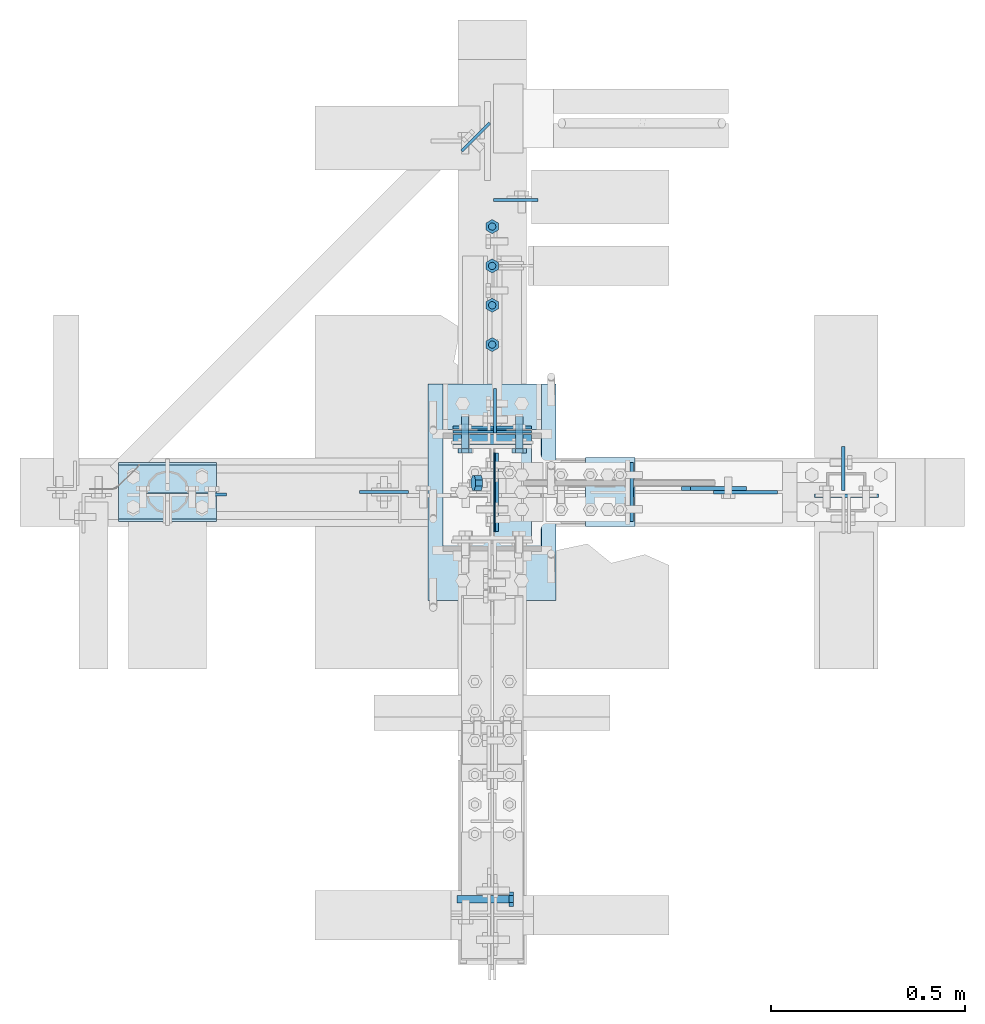
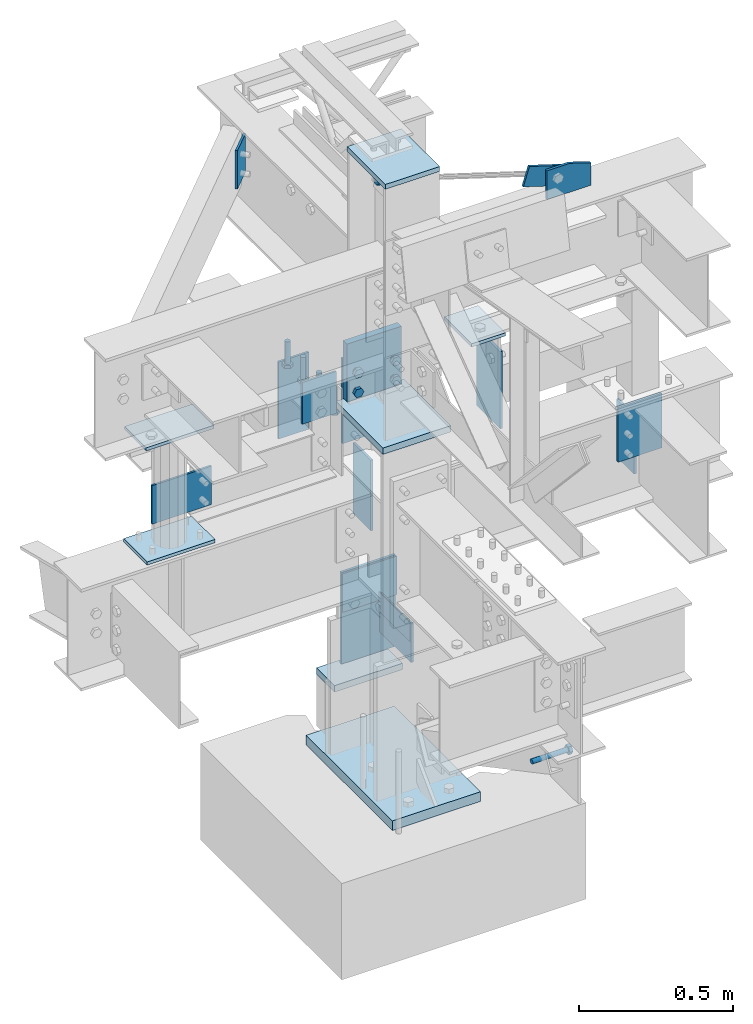
# Not in any storey, part 4 of 8: 24 plates, 9 mechanical fasteners, 13 elements without a shape of their own.
"""IFC2X3 building model written with IfcOpenShell, lengths in inches."""

from ifc_helpers import new_model, entity, si_unit, converted_unit, frame, origin_with_axes, origin_2d_with_axis, place, context, project, spatial, polyline, circle, outline, extrude, faceted_brep, source, transform, mapped, material, type_object, type_shapes, element, aggregate, save


model = new_model("IFC2X3")

# Units and contexts
model_context = context("Model", 3, precision=1e-05, world=origin_with_axes())
ifc_project = project(units=[converted_unit("LENGTHUNIT", "INCH", entity("IfcLengthMeasure", 25.4), si_unit("LENGTHUNIT", "METRE", prefix="MILLI"), dimensions=[1, 0, 0, 0, 0, 0, 0]), si_unit("PLANEANGLEUNIT", "RADIAN"), si_unit("MASSUNIT", "GRAM", prefix="KILO"), si_unit("TIMEUNIT", "SECOND"), si_unit("AREAUNIT", "SQUARE_METRE"), si_unit("PRESSUREUNIT", "PASCAL"), si_unit("FORCEUNIT", "NEWTON"), si_unit("THERMODYNAMICTEMPERATUREUNIT", "DEGREE_CELSIUS")], contexts=[model_context])

# Site, building
site_placement = place(None, origin_with_axes())
site = spatial("IfcSite", under=ifc_project, at=site_placement, CompositionType="ELEMENT")
building_placement = place(site_placement, origin_with_axes())
building = spatial("IfcBuilding", under=site, at=building_placement, Name="Building", CompositionType="ELEMENT")

# Assembly, plates
assembly_1_placement = place(building_placement, frame((23.9999999999998, 0.9375, 83.0), z_axis=(0.0, 1.0, 0.0), x_axis=(-0.954479957764932, 0.0, 0.29827505800024)))
assembly_1 = element("IfcElementAssembly", 1, at=assembly_1_placement, inside=building, Name="4-7", PredefinedType="NOTDEFINED")
ifc_material_1 = material()
plate_type_1 = type_object("IfcPlateType", Name="Plate (Complex)", PredefinedType="SHEET", material=ifc_material_1)
shared_shape_1 = source(origin_with_axes(), model_context, "Body", "Brep", [
    faceted_brep([(-0.375, 0.0, -1.0625), (-0.375, -0.438, -1.5), (-0.375, -1.0625, -1.5), (-0.375, -1.5, -1.0625), (-0.375, -1.5, -0.438), (-0.375, -1.0625, 0.0), (-0.375, -0.438, 0.0), (-0.375, 0.0, -0.438), (0.375, 0.0, -0.438), (0.375, -0.438, 0.0), (0.375, -1.0625, 0.0), (0.375, -1.5, -0.438), (0.375, -1.5, -1.0625), (0.375, -1.0625, -1.5), (0.375, -0.438, -1.5), (0.375, 0.0, -1.0625)], [[[0, 1, 2, 3, 4, 5, 6, 7]], [[8, 9, 10, 11, 12, 13, 14, 15]], [[15, 14, 1, 0]], [[14, 13, 2, 1]], [[13, 12, 3, 2]], [[12, 11, 4, 3]], [[11, 10, 5, 4]], [[10, 9, 6, 5]], [[9, 8, 7, 6]], [[8, 15, 0, 7]]]),
])
type_shapes(plate_type_1, [shared_shape_1])
plate_1_placement = place(assembly_1_placement, frame((26.7744260805885, 0.749994139208951, 0.75), z_axis=(0.0, 0.0, 1.0), x_axis=(1.0, 0.0, 0.0)))
plate_1 = element("IfcPlate", 2, at=plate_1_placement, type_object=plate_type_1, Name="p16", ObjectType="Vertical brace", context=model_context, shape_type="MappedRepresentation", body=[
    mapped(shared_shape_1, transform((0.0, 0.0, 0.0), scale=1.0)),
])
plate_type_2 = type_object("IfcPlateType", Name="Plate (0-3x0-6)", PredefinedType="SHEET", material=ifc_material_1)
shared_shape_2 = source(origin_with_axes(), model_context, "Body", "Brep", [
    faceted_brep([(-0.1875, 0.0, -3.0), (-0.1875, -6.0, -3.0), (-0.1875, -6.0, 0.0), (-0.1875, 0.0, 0.0), (0.1875, 0.0, 0.0), (0.1875, -6.0, 0.0), (0.1875, -6.0, -3.0), (0.1875, 0.0, -3.0)], [[[0, 1, 2, 3]], [[4, 5, 6, 7]], [[7, 6, 1, 0]], [[6, 5, 2, 1]], [[5, 4, 3, 2]], [[4, 7, 0, 3]]]),
])
type_shapes(plate_type_2, [shared_shape_2])
plate_2_placement = place(assembly_1_placement, frame((4.50000040893256, -1.49999996688446, -0.562499999999998), z_axis=(0.0, -1.0, 0.0), x_axis=(0.0, 0.0, -1.0)))
plate_2 = element("IfcPlate", 3, at=plate_2_placement, type_object=plate_type_2, Name="p2", ObjectType="Vertical brace", context=model_context, shape_type="MappedRepresentation", body=[
    mapped(shared_shape_2, transform((0.0, 0.0, 0.0), scale=1.0)),
])
aggregate(assembly_1, [plate_1, plate_2])

assembly_2_placement = place(building_placement, frame((0.0, 0.0, -1.5), z_axis=(0.0, -1.0, 0.0), x_axis=(0.0, 0.0, 1.0)))
assembly_2 = element("IfcElementAssembly", 4, at=assembly_2_placement, inside=building, Name="1-1", PredefinedType="NOTDEFINED")
ifc_material_2 = material()
plate_type_3 = type_object("IfcPlateType", Name="Plate (1-10x1-1)", PredefinedType="SHEET", material=ifc_material_2)
shared_shape_3 = source(origin_with_axes(), model_context, "Body", "Brep", [
    faceted_brep([(-0.75, 6.5, -11.0), (-0.75, -6.5, -11.0), (-0.75, -6.5, 11.0), (-0.75, 6.5, 11.0), (0.75, 6.5, 11.0), (0.75, -6.5, 11.0), (0.75, -6.5, -11.0), (0.75, 6.5, -11.0)], [[[0, 1, 2, 3]], [[4, 5, 6, 7]], [[7, 6, 1, 0]], [[6, 5, 2, 1]], [[5, 4, 3, 2]], [[4, 7, 0, 3]]]),
])
type_shapes(plate_type_3, [shared_shape_3])
plate_3_placement = place(assembly_2_placement, frame((0.75, 0.0, 0.0), z_axis=(0.0, 0.0, -1.0), x_axis=(1.0, 0.0, 0.0)))
plate_3 = element("IfcPlate", 5, at=plate_3_placement, type_object=plate_type_3, Name="p33", ObjectType="Column", context=model_context, shape_type="MappedRepresentation", body=[
    mapped(shared_shape_3, transform((0.0, 0.0, 0.0), scale=1.0)),
])
plate_type_4 = type_object("IfcPlateType", Name="Plate (1-2 1/4x0-8)", PredefinedType="SHEET", material=ifc_material_1)
shared_shape_4 = source(origin_with_axes(), model_context, "Body", "Brep", [
    faceted_brep([(-0.1875, 4.0, -14.25), (-0.1875, -4.0, -14.25), (-0.1875, -4.0, 0.0), (-0.1875, 4.0, 0.0), (0.1875, 4.0, 0.0), (0.1875, -4.0, 0.0), (0.1875, -4.0, -14.25), (0.1875, 4.0, -14.25)], [[[0, 1, 2, 3]], [[4, 5, 6, 7]], [[7, 6, 1, 0]], [[6, 5, 2, 1]], [[5, 4, 3, 2]], [[4, 7, 0, 3]]]),
])
type_shapes(plate_type_4, [shared_shape_4])
plate_4_placement = place(assembly_2_placement, frame((14.5, 0.0, -6.54250001907349), z_axis=(-1.0, 0.0, 0.0), x_axis=(0.0, 0.0, -1.0)))
plate_4 = element("IfcPlate", 6, at=plate_4_placement, type_object=plate_type_4, Name="p39", ObjectType="Column", context=model_context, shape_type="MappedRepresentation", body=[
    mapped(shared_shape_4, transform((0.0, 0.0, 0.0), scale=1.0)),
])
plate_type_5 = type_object("IfcPlateType", Name="Plate (0-8x0-6)", PredefinedType="SHEET", material=ifc_material_1)
shared_shape_5 = source(origin_with_axes(), model_context, "Body", "Brep", [
    faceted_brep([(-0.1875, 0.0, -8.0), (-0.1875, -6.0, -8.0), (-0.1875, -6.0, 0.0), (-0.1875, 0.0, 0.0), (0.1875, 0.0, 0.0), (0.1875, -6.0, 0.0), (0.1875, -6.0, -8.0), (0.1875, 0.0, -8.0)], [[[0, 1, 2, 3]], [[4, 5, 6, 7]], [[7, 6, 1, 0]], [[6, 5, 2, 1]], [[5, 4, 3, 2]], [[4, 7, 0, 3]]]),
])
type_shapes(plate_type_5, [shared_shape_5])
plate_5_placement = place(assembly_2_placement, frame((25.5, -0.462500005960464, 4.0), z_axis=(0.0, 0.0, 1.0), x_axis=(0.0, -1.0, 0.0)))
plate_5 = element("IfcPlate", 7, at=plate_5_placement, type_object=plate_type_5, Name="p40", ObjectType="Column", context=model_context, shape_type="MappedRepresentation", body=[
    mapped(shared_shape_5, transform((0.0, 0.0, 0.0), scale=1.0)),
])
plate_type_6 = type_object("IfcPlateType", Name="Plate (0-10x4 5/8)", PredefinedType="SHEET", material=ifc_material_1)
shared_shape_6 = source(origin_with_axes(), model_context, "Body", "Brep", [
    faceted_brep([(-0.5, 0.0, -10.0), (-0.5, -4.625, -10.0), (-0.5, -4.625, 0.0), (-0.5, 0.0, 0.0), (0.5, 0.0, 0.0), (0.5, -4.625, 0.0), (0.5, -4.625, -10.0), (0.5, 0.0, -10.0)], [[[0, 1, 2, 3]], [[4, 5, 6, 7]], [[7, 6, 1, 0]], [[6, 5, 2, 1]], [[5, 4, 3, 2]], [[4, 7, 0, 3]]]),
])
type_shapes(plate_type_6, [shared_shape_6])
plate_6_placement = place(assembly_2_placement, frame((11.0, -5.0, -6.35500001907349), z_axis=(0.0, -1.0, 0.0), x_axis=(1.0, 0.0, 0.0)))
plate_6 = element("IfcPlate", 8, at=plate_6_placement, type_object=plate_type_6, Name="p36", ObjectType="Column", context=model_context, shape_type="MappedRepresentation", body=[
    mapped(shared_shape_6, transform((0.0, 0.0, 0.0), scale=1.0)),
])
aggregate(assembly_2, [plate_3, plate_4, plate_5, plate_6])

assembly_3_placement = place(building_placement, frame((0.0, 0.0, 21.0), z_axis=(0.0, -1.0, 0.0), x_axis=(0.0, 0.0, 1.0)))
assembly_3 = element("IfcElementAssembly", 9, at=assembly_3_placement, inside=building, Name="1-2", PredefinedType="NOTDEFINED")
plate_type_7 = type_object("IfcPlateType", Name="Plate (0-8x0-3)", PredefinedType="SHEET", material=ifc_material_1)
shared_shape_7 = source(origin_with_axes(), model_context, "Body", "Brep", [
    faceted_brep([(-0.0625, 0.0, -8.0), (-0.0625, -3.0, -8.0), (-0.0625, -3.0, 0.0), (-0.0625, 0.0, 0.0), (0.0625, 0.0, 0.0), (0.0625, -3.0, 0.0), (0.0625, -3.0, -8.0), (0.0625, 0.0, -8.0)], [[[0, 1, 2, 3]], [[4, 5, 6, 7]], [[7, 6, 1, 0]], [[6, 5, 2, 1]], [[5, 4, 3, 2]], [[4, 7, 0, 3]]]),
])
type_shapes(plate_type_7, [shared_shape_7])
plate_7_placement = place(assembly_3_placement, frame((3.25, -0.234999999403954, 4.0), z_axis=(0.0, 0.0, 1.0), x_axis=(0.0, -1.0, 0.0)))
plate_7 = element("IfcPlate", 10, at=plate_7_placement, type_object=plate_type_7, Name="p44", ObjectType="Column", context=model_context, shape_type="MappedRepresentation", body=[
    mapped(shared_shape_7, transform((0.0, 0.0, 0.0), scale=1.0)),
])
plate_type_8 = type_object("IfcPlateType", Name="Plate (1-1 1/4x0-8)", PredefinedType="SHEET", material=ifc_material_1)
shared_shape_8 = source(origin_with_axes(), model_context, "Body", "Brep", [
    faceted_brep([(-0.1875, 4.0, -13.25), (-0.1875, -4.0, -13.25), (-0.1875, -4.0, 0.0), (-0.1875, 4.0, 0.0), (0.1875, 4.0, 0.0), (0.1875, -4.0, 0.0), (0.1875, -4.0, -13.25), (0.1875, 4.0, -13.25)], [[[0, 1, 2, 3]], [[4, 5, 6, 7]], [[7, 6, 1, 0]], [[6, 5, 2, 1]], [[5, 4, 3, 2]], [[4, 7, 0, 3]]]),
])
type_shapes(plate_type_8, [shared_shape_8])
plate_8_placement = place(assembly_3_placement, frame((26.5, 0.0, -6.21750020980835), z_axis=(-1.0, 0.0, 0.0), x_axis=(0.0, 0.0, -1.0)))
plate_8 = element("IfcPlate", 11, at=plate_8_placement, type_object=plate_type_8, Name="p47", ObjectType="Column", context=model_context, shape_type="MappedRepresentation", body=[
    mapped(shared_shape_8, transform((0.0, 0.0, 0.0), scale=1.0)),
])
plate_type_9 = type_object("IfcPlateType", Name="Plate (1-0x0-10)", PredefinedType="SHEET", material=ifc_material_1)
shared_shape_9 = source(origin_with_axes(), model_context, "Body", "Brep", [
    faceted_brep([(-0.5, 3.98, -6.095), (-0.5, -6.02, -6.095), (-0.5, -6.02, 5.905), (-0.5, 3.98, 5.905), (0.5, 3.98, 5.905), (0.5, -6.02, 5.905), (0.5, -6.02, -6.095), (0.5, 3.98, -6.095)], [[[0, 1, 2, 3]], [[4, 5, 6, 7]], [[7, 6, 1, 0]], [[6, 5, 2, 1]], [[5, 4, 3, 2]], [[4, 7, 0, 3]]]),
])
type_shapes(plate_type_9, [shared_shape_9])
plate_9_placement = place(assembly_3_placement, frame((33.0, 1.01999998092651, -0.0949997901916504), z_axis=(0.0, 0.0, -1.0), x_axis=(-1.0, 0.0, 0.0)))
plate_9 = element("IfcPlate", 12, at=plate_9_placement, type_object=plate_type_9, Name="p3", ObjectType="Column", context=model_context, shape_type="MappedRepresentation", body=[
    mapped(shared_shape_9, transform((0.0, 0.0, 0.0), scale=1.0)),
])
plate_type_10 = type_object("IfcPlateType", Name="Plate (0-8x0-6)", PredefinedType="SHEET", material=ifc_material_1)
shared_shape_10 = source(origin_with_axes(), model_context, "Body", "Brep", [
    faceted_brep([(-0.125, 0.0, -8.0), (-0.125, -6.0, -8.0), (-0.125, -6.0, 0.0), (-0.125, 0.0, 0.0), (0.125, 0.0, 0.0), (0.125, -6.0, 0.0), (0.125, -6.0, -8.0), (0.125, 0.0, -8.0)], [[[0, 1, 2, 3]], [[4, 5, 6, 7]], [[7, 6, 1, 0]], [[6, 5, 2, 1]], [[5, 4, 3, 2]], [[4, 7, 0, 3]]]),
])
type_shapes(plate_type_10, [shared_shape_10])
plate_10_placement = place(assembly_3_placement, frame((6.25, -4.0, -6.15500020980835), z_axis=(0.0, -1.0, 0.0), x_axis=(0.0, 0.0, -1.0)))
plate_10 = element("IfcPlate", 13, at=plate_10_placement, type_object=plate_type_10, Name="p43", ObjectType="Column", context=model_context, shape_type="MappedRepresentation", body=[
    mapped(shared_shape_10, transform((0.0, 0.0, 0.0), scale=1.0)),
])
plate_type_11 = type_object("IfcPlateType", Name="Plate (4 1/2x0-11)", PredefinedType="SHEET", material=ifc_material_1)
shared_shape_11 = source(origin_with_axes(), model_context, "Body", "Brep", [
    faceted_brep([(-0.15625, 0.0, -4.5), (-0.15625, -11.0, -4.5), (-0.15625, -11.0, 0.0), (-0.15625, 0.0, 0.0), (0.1563, 0.0, 0.0), (0.1563, -11.0, 0.0), (0.1563, -11.0, -4.5), (0.1563, 0.0, -4.5)], [[[0, 1, 2, 3]], [[4, 5, 6, 7]], [[7, 6, 1, 0]], [[6, 5, 2, 1]], [[5, 4, 3, 2]], [[4, 7, 0, 3]]]),
])
type_shapes(plate_type_11, [shared_shape_11])
plate_11_placement = place(assembly_3_placement, frame((22.5, -0.30375000834465, -6.03000020980835), z_axis=(0.0, 0.0, 1.0), x_axis=(0.0, -1.0, 0.0)))
plate_11 = element("IfcPlate", 14, at=plate_11_placement, type_object=plate_type_11, Name="p52", ObjectType="Column", context=model_context, shape_type="MappedRepresentation", body=[
    mapped(shared_shape_11, transform((0.0, 0.0, 0.0), scale=1.0)),
])
aggregate(assembly_3, [plate_7, plate_8, plate_9, plate_10, plate_11])

assembly_4_placement = place(building_placement, frame((0.0, 0.0, 54.5), z_axis=(0.0, -1.0, 0.0), x_axis=(0.0, 0.0, 1.0)))
assembly_4 = element("IfcElementAssembly", 15, at=assembly_4_placement, inside=building, Name="1-3", PredefinedType="NOTDEFINED")
plate_type_12 = type_object("IfcPlateType", Name="Plate (9 3/4x0-8)", PredefinedType="SHEET", material=ifc_material_2)
shared_shape_12 = source(origin_with_axes(), model_context, "Body", "Brep", [
    faceted_brep([(-0.375, 4.0, -4.875), (-0.375, -4.0, -4.875), (-0.375, -4.0, 4.875), (-0.375, 4.0, 4.875), (0.375, 4.0, 4.875), (0.375, -4.0, 4.875), (0.375, -4.0, -4.875), (0.375, 4.0, -4.875)], [[[0, 1, 2, 3]], [[4, 5, 6, 7]], [[7, 6, 1, 0]], [[6, 5, 2, 1]], [[5, 4, 3, 2]], [[4, 7, 0, 3]]]),
])
type_shapes(plate_type_12, [shared_shape_12])
plate_12_placement = place(assembly_4_placement, frame((39.625, 0.0, 0.0), z_axis=(0.0, 0.0, -1.0), x_axis=(-1.0, 0.0, 0.0)))
plate_12 = element("IfcPlate", 16, at=plate_12_placement, type_object=plate_type_12, Name="p26", ObjectType="Column", context=model_context, shape_type="MappedRepresentation", body=[
    mapped(shared_shape_12, transform((0.0, 0.0, 0.0), scale=1.0)),
])
plate_type_13 = type_object("IfcPlateType", Name="Plate (0-9x0-8)", PredefinedType="SHEET", material=ifc_material_1)
shared_shape_13 = source(origin_with_axes(), model_context, "Body", "Brep", [
    faceted_brep([(-0.5, 4.0, -9.0), (-0.5, -4.0, -9.0), (-0.5, -4.0, 0.0), (-0.5, 4.0, 0.0), (0.5, 4.0, 0.0), (0.5, -4.0, 0.0), (0.5, -4.0, -9.0), (0.5, 4.0, -9.0)], [[[0, 1, 2, 3]], [[4, 5, 6, 7]], [[7, 6, 1, 0]], [[6, 5, 2, 1]], [[5, 4, 3, 2]], [[4, 7, 0, 3]]]),
])
type_shapes(plate_type_13, [shared_shape_13])
plate_13_placement = place(assembly_4_placement, frame((0.236220479011536, 0.0, -5.36499977111816), z_axis=(-1.0, 0.0, 0.0), x_axis=(0.0, 0.0, -1.0)))
plate_13 = element("IfcPlate", 17, at=plate_13_placement, type_object=plate_type_13, Name="p22", ObjectType="Column", context=model_context, shape_type="MappedRepresentation", body=[
    mapped(shared_shape_13, transform((0.0, 0.0, 0.0), scale=1.0)),
])
aggregate(assembly_4, [plate_12, plate_13])

# Assembly, plate
assembly_5_placement = place(building_placement, frame((0.0, 0.0, 46.0), z_axis=(0.0, 0.0, 1.0), x_axis=(0.0, 1.0, 0.0)))
assembly_5 = element("IfcElementAssembly", 18, at=assembly_5_placement, inside=building, Name="2-3", PredefinedType="NOTDEFINED")
plate_type_14 = type_object("IfcPlateType", Name="Plate (4 1/2x1-0)", PredefinedType="SHEET", material=ifc_material_1)
shared_shape_14 = source(origin_with_axes(), model_context, "Body", "Brep", [
    faceted_brep([(-0.15625, 0.0, -4.5), (-0.15625, -12.0, -4.5), (-0.15625, -12.0, 0.0), (-0.15625, 0.0, 0.0), (0.1563, 0.0, 0.0), (0.1563, -12.0, 0.0), (0.1563, -12.0, -4.5), (0.1563, 0.0, -4.5)], [[[0, 1, 2, 3]], [[4, 5, 6, 7]], [[7, 6, 1, 0]], [[6, 5, 2, 1]], [[5, 4, 3, 2]], [[4, 7, 0, 3]]]),
])
type_shapes(plate_type_14, [shared_shape_14])
plate_14_placement = place(assembly_5_placement, frame((29.71875, -0.14750000834465, -1.5), z_axis=(0.0, 1.0, 0.0), x_axis=(-1.0, 0.0, 0.0)))
plate_14 = element("IfcPlate", 19, at=plate_14_placement, type_object=plate_type_14, Name="p10", ObjectType="Beam", context=model_context, shape_type="MappedRepresentation", body=[
    mapped(shared_shape_14, transform((0.0, 0.0, 0.0), scale=1.0)),
])
aggregate(assembly_5, [plate_14])

assembly_6_placement = place(building_placement, frame((0.0, 0.0, 46.0), z_axis=(0.0, 0.0, 1.0), x_axis=(1.0, 0.0, 0.0)))
assembly_6 = element("IfcElementAssembly", 20, at=assembly_6_placement, inside=building, Name="2-5", PredefinedType="NOTDEFINED")
plate_type_15 = type_object("IfcPlateType", Name="Plate (4 1/2x0-9)", PredefinedType="SHEET", material=ifc_material_1)
shared_shape_15 = source(origin_with_axes(), model_context, "Body", "Brep", [
    faceted_brep([(-0.1875, 0.0, -4.5), (-0.1875, -9.0, -4.5), (-0.1875, -9.0, 0.0), (-0.1875, 0.0, 0.0), (0.1875, 0.0, 0.0), (0.1875, -9.0, 0.0), (0.1875, -9.0, -4.5), (0.1875, 0.0, -4.5)], [[[0, 1, 2, 3]], [[4, 5, 6, 7]], [[7, 6, 1, 0]], [[6, 5, 2, 1]], [[5, 4, 3, 2]], [[4, 7, 0, 3]]]),
])
type_shapes(plate_type_15, [shared_shape_15])
plate_15_placement = place(assembly_6_placement, frame((35.6974999979138, 0.14750000834465, -4.5), z_axis=(0.0, -1.0, 0.0), x_axis=(1.0, 0.0, 0.0)))
plate_15 = element("IfcPlate", 21, at=plate_15_placement, type_object=plate_type_15, Name="p54", ObjectType="Beam", context=model_context, shape_type="MappedRepresentation", body=[
    mapped(shared_shape_15, transform((0.0, 0.0, 0.0), scale=1.0)),
])
aggregate(assembly_6, [plate_15])

assembly_7_placement = place(building_placement, frame((36.0, 0.0, 58.0), z_axis=(0.0, 0.0, 1.0), x_axis=(-1.0, 0.0, 0.0)))
assembly_7 = element("IfcElementAssembly", 22, at=assembly_7_placement, inside=building, Name="4-3", PredefinedType="NOTDEFINED")
plate_type_16 = type_object("IfcPlateType", Name="Plate (1-0x0-6)", PredefinedType="SHEET", material=ifc_material_1)
shared_shape_16 = source(origin_with_axes(), model_context, "Body", "Brep", [
    faceted_brep([(-0.1875, 0.0, -12.0), (-0.1875, -6.0, -12.0), (-0.1875, -6.0, 0.0), (-0.1875, 0.0, 0.0), (0.1875, 0.0, 0.0), (0.1875, -6.0, 0.0), (0.1875, -6.0, -12.0), (0.1875, 0.0, -12.0)], [[[0, 1, 2, 3]], [[4, 5, 6, 7]], [[7, 6, 1, 0]], [[6, 5, 2, 1]], [[5, 4, 3, 2]], [[4, 7, 0, 3]]]),
])
type_shapes(plate_type_16, [shared_shape_16])
plate_16_placement = place(assembly_7_placement, frame((21.8125, 3.0, -9.0), z_axis=(0.0, 0.0, -1.0), x_axis=(-1.0, 0.0, 0.0)))
plate_16 = element("IfcPlate", 23, at=plate_16_placement, type_object=plate_type_16, Name="p1", ObjectType="Beam", context=model_context, shape_type="MappedRepresentation", body=[
    mapped(shared_shape_16, transform((0.0, 0.0, 0.0), scale=1.0)),
])
aggregate(assembly_7, [plate_16])

# Assembly, plates
assembly_8_placement = place(building_placement, frame((-33.0, 0.0, 46.0), z_axis=(-1.0, 0.0, 0.0), x_axis=(0.0, 0.0, 1.0)))
assembly_8 = element("IfcElementAssembly", 24, at=assembly_8_placement, inside=building, Name="4-2", PredefinedType="NOTDEFINED")
plate_type_17 = type_object("IfcPlateType", Name="Plate (0-10x0-6)", PredefinedType="SHEET", material=ifc_material_1)
shared_shape_17 = source(origin_with_axes(), model_context, "Body", "Brep", [
    faceted_brep([(-0.25, 3.0, -5.25), (-0.25, -3.0, -5.25), (-0.25, -3.0, 4.75), (-0.25, 3.0, 4.75), (0.25, 3.0, 4.75), (0.25, -3.0, 4.75), (0.25, -3.0, -5.25), (0.25, 3.0, -5.25)], [[[0, 1, 2, 3]], [[4, 5, 6, 7]], [[7, 6, 1, 0]], [[6, 5, 2, 1]], [[5, 4, 3, 2]], [[4, 7, 0, 3]]]),
])
type_shapes(plate_type_17, [shared_shape_17])
plate_17_placement = place(assembly_8_placement, frame((0.25, 0.0, -0.25), z_axis=(0.0, 0.0, -1.0), x_axis=(1.0, 0.0, 0.0)))
plate_17 = element("IfcPlate", 25, at=plate_17_placement, type_object=plate_type_17, Name="p20", ObjectType="Column", context=model_context, shape_type="MappedRepresentation", body=[
    mapped(shared_shape_17, transform((0.0, 0.0, 0.0), scale=1.0)),
])
plate_type_18 = type_object("IfcPlateType", Name="Plate (0-10x5 1/2)", PredefinedType="SHEET", material=ifc_material_1)
shared_shape_18 = source(origin_with_axes(), model_context, "Body", "Brep", [
    faceted_brep([(-0.25, 2.75, -5.0), (-0.25, -2.75, -5.0), (-0.25, -2.75, 5.0), (-0.25, 2.75, 5.0), (0.25, 2.75, 5.0), (0.25, -2.75, 5.0), (0.25, -2.75, -5.0), (0.25, 2.75, -5.0)], [[[0, 1, 2, 3]], [[4, 5, 6, 7]], [[7, 6, 1, 0]], [[6, 5, 2, 1]], [[5, 4, 3, 2]], [[4, 7, 0, 3]]]),
])
type_shapes(plate_type_18, [shared_shape_18])
plate_18_placement = place(assembly_8_placement, frame((17.875, 0.0, 0.0), z_axis=(0.0, 0.0, -1.0), x_axis=(-1.0, 0.0, 0.0)))
plate_18 = element("IfcPlate", 26, at=plate_18_placement, type_object=plate_type_18, Name="p13", ObjectType="Column", context=model_context, shape_type="MappedRepresentation", body=[
    mapped(shared_shape_18, transform((0.0, 0.0, 0.0), scale=1.0)),
])
plate_type_19 = type_object("IfcPlateType", Name="Plate (8 3/4x0-6)", PredefinedType="SHEET", material=ifc_material_1)
shared_shape_19 = source(origin_with_axes(), model_context, "Body", "Brep", [
    faceted_brep([(-0.15625, 0.0, -8.75), (-0.15625, -6.0, -8.75), (-0.15625, -6.0, 0.0), (-0.15625, 0.0, 0.0), (0.1563, 0.0, 0.0), (0.1563, -6.0, 0.0), (0.1563, -6.0, -8.75), (0.1563, 0.0, -8.75)], [[[0, 1, 2, 3]], [[4, 5, 6, 7]], [[7, 6, 1, 0]], [[6, 5, 2, 1]], [[5, 4, 3, 2]], [[4, 7, 0, 3]]]),
])
type_shapes(plate_type_19, [shared_shape_19])
plate_19_placement = place(assembly_8_placement, frame((10.0, -0.24125000089407, 2.75), z_axis=(0.0, 0.0, 1.0), x_axis=(0.0, -1.0, 0.0)))
plate_19 = element("IfcPlate", 27, at=plate_19_placement, type_object=plate_type_19, Name="p11", ObjectType="Column", context=model_context, shape_type="MappedRepresentation", body=[
    mapped(shared_shape_19, transform((0.0, 0.0, 0.0), scale=1.0)),
])
aggregate(assembly_8, [plate_17, plate_18, plate_19])

# Assembly, plate
assembly_9_placement = place(building_placement, frame((36.0, 0.0, 46.0), z_axis=(0.0, 0.0, 1.0), x_axis=(0.0, -1.0, 0.0)))
assembly_9 = element("IfcElementAssembly", 28, at=assembly_9_placement, inside=building, Name="3-1", PredefinedType="NOTDEFINED")
plate_type_20 = type_object("IfcPlateType", Name="Plate (8 1/2x6 1/2)", PredefinedType="SHEET", material=ifc_material_1)
shared_shape_20 = source(origin_with_axes(), model_context, "Body", "Brep", [
    faceted_brep([(-0.1875, 3.25, -8.5), (-0.1875, -3.25, -8.5), (-0.1875, -3.25, 0.0), (-0.1875, 3.25, 0.0), (0.1875, 3.25, 0.0), (0.1875, -3.25, 0.0), (0.1875, -3.25, -8.5), (0.1875, 3.25, -8.5)], [[[0, 1, 2, 3]], [[4, 5, 6, 7]], [[7, 6, 1, 0]], [[6, 5, 2, 1]], [[5, 4, 3, 2]], [[4, 7, 0, 3]]]),
])
type_shapes(plate_type_20, [shared_shape_20])
plate_20_placement = place(assembly_9_placement, frame((0.375, 0.0, -1.75), z_axis=(0.0, 0.0, 1.0), x_axis=(-1.0, 0.0, 0.0)))
plate_20 = element("IfcPlate", 29, at=plate_20_placement, type_object=plate_type_20, Name="p19", ObjectType="Beam", context=model_context, shape_type="MappedRepresentation", body=[
    mapped(shared_shape_20, transform((0.0, 0.0, 0.0), scale=1.0)),
])
aggregate(assembly_9, [plate_20])

assembly_10_placement = place(building_placement, frame((0.0, 0.0, 80.0), z_axis=(0.0, 0.0, 1.0), x_axis=(-1.0, 0.0, 0.0)))
assembly_10 = element("IfcElementAssembly", 30, at=assembly_10_placement, inside=building, Name="2-7", PredefinedType="NOTDEFINED")
plate_type_21 = type_object("IfcPlateType", Name="Plate (6 1/2x0-5)", PredefinedType="SHEET", material=ifc_material_1)
shared_shape_21 = source(origin_with_axes(), model_context, "Body", "Brep", [
    faceted_brep([(-0.15625, 0.0, -6.5), (-0.15625, -5.0, -6.5), (-0.15625, -5.0, 0.0), (-0.15625, 0.0, 0.0), (0.1563, 0.0, 0.0), (0.1563, -5.0, 0.0), (0.1563, -5.0, -6.5), (0.1563, 0.0, -6.5)], [[[0, 1, 2, 3]], [[4, 5, 6, 7]], [[7, 6, 1, 0]], [[6, 5, 2, 1]], [[5, 4, 3, 2]], [[4, 7, 0, 3]]]),
])
type_shapes(plate_type_21, [shared_shape_21])
plate_21_placement = place(assembly_10_placement, frame((13.5, 0.0, -15.8800010681152), z_axis=(0.0, 0.0, 1.0), x_axis=(0.0, -1.0, 0.0)))
plate_21 = element("IfcPlate", 31, at=plate_21_placement, type_object=plate_type_21, Name="p9", ObjectType="Beam", context=model_context, shape_type="MappedRepresentation", body=[
    mapped(shared_shape_21, transform((0.0, 0.0, 0.0), scale=1.0)),
])
aggregate(assembly_10, [plate_21])

assembly_11_placement = place(building_placement, frame((0.0, 0.0, 80.0), z_axis=(0.0, 0.0, 1.0), x_axis=(0.0, 1.0, 0.0)))
assembly_11 = element("IfcElementAssembly", 32, at=assembly_11_placement, inside=building, Name="2-6", PredefinedType="NOTDEFINED")
plate_type_22 = type_object("IfcPlateType", Name="Plate (0-4x0-6)", PredefinedType="SHEET", material=ifc_material_1)
shared_shape_22 = source(origin_with_axes(), model_context, "Body", "Brep", [
    faceted_brep([(-0.15625, 0.0, -4.0), (-0.15625, -6.0, -4.0), (-0.15625, -6.0, 0.0), (-0.15625, 0.0, 0.0), (0.1563, 0.0, 0.0), (0.1563, -6.0, 0.0), (0.1563, -6.0, -4.0), (0.1563, 0.0, -4.0)], [[[0, 1, 2, 3]], [[4, 5, 6, 7]], [[7, 6, 1, 0]], [[6, 5, 2, 1]], [[5, 4, 3, 2]], [[4, 7, 0, 3]]]),
])
type_shapes(plate_type_22, [shared_shape_22])
plate_22_placement = place(assembly_11_placement, frame((37.521045031785, 0.257985744020722, -4.5), z_axis=(0.707106796640858, -0.707106765732237, 0.0), x_axis=(0.707106765732237, 0.707106796640858, 0.0)))
plate_22 = element("IfcPlate", 33, at=plate_22_placement, type_object=plate_type_22, Name="p14", ObjectType="Beam", context=model_context, shape_type="MappedRepresentation", body=[
    mapped(shared_shape_22, transform((0.0, 0.0, 0.0), scale=1.0)),
])
aggregate(assembly_11, [plate_22])

assembly_12_placement = place(building_placement, frame((0.0, 0.0, 80.0), z_axis=(0.0, 0.0, 1.0), x_axis=(1.0, 0.0, 0.0)))
assembly_12 = element("IfcElementAssembly", 34, at=assembly_12_placement, inside=building, Name="2-8", PredefinedType="NOTDEFINED")
plate_type_23 = type_object("IfcPlateType", Name="Plate (Complex)", PredefinedType="SHEET", material=ifc_material_1)
shared_shape_23 = source(origin_with_axes(), model_context, "Body", "Brep", [
    faceted_brep([(-0.1875, 0.0, -3.375), (-0.1875, -1.0, -6.5), (-0.1875, -4.5, -6.5), (-0.1875, -4.5, 0.0), (-0.1875, 0.0, 0.0), (0.1875, 0.0, 0.0), (0.1875, -4.5, 0.0), (0.1875, -4.5, -6.5), (0.1875, -1.0, -6.5), (0.1875, 0.0, -3.375)], [[[0, 1, 2, 3, 4]], [[5, 6, 7, 8, 9]], [[9, 8, 1, 0]], [[8, 7, 2, 1]], [[7, 6, 3, 2]], [[6, 5, 4, 3]], [[5, 9, 0, 4]]]),
])
type_shapes(plate_type_23, [shared_shape_23])
plate_23_placement = place(assembly_12_placement, frame((22.5, 0.0, 4.5), z_axis=(-1.0, 0.0, 0.0), x_axis=(0.0, -1.0, 0.0)))
plate_23 = element("IfcPlate", 35, at=plate_23_placement, type_object=plate_type_23, Name="p49", ObjectType="Beam", context=model_context, shape_type="MappedRepresentation", body=[
    mapped(shared_shape_23, transform((0.0, 0.0, 0.0), scale=1.0)),
])
aggregate(assembly_12, [plate_23])

assembly_13_placement = place(building_placement, frame((14.0, 0.0, 49.0), z_axis=(0.0, -1.0, 0.0), x_axis=(0.0, 0.0, 1.0)))
assembly_13 = element("IfcElementAssembly", 36, at=assembly_13_placement, inside=building, Name="4-4", PredefinedType="NOTDEFINED")
plate_type_24 = type_object("IfcPlateType", Name="Plate (0-5x0-7)", PredefinedType="SHEET", material=ifc_material_1)
shared_shape_24 = source(origin_with_axes(), model_context, "Body", "Brep", [
    faceted_brep([(-0.25, 0.0, -5.0), (-0.25, -7.0, -5.0), (-0.25, -7.0, 0.0), (-0.25, 0.0, 0.0), (0.25, 0.0, 0.0), (0.25, -7.0, 0.0), (0.25, -7.0, -5.0), (0.25, 0.0, -5.0)], [[[0, 1, 2, 3]], [[4, 5, 6, 7]], [[7, 6, 1, 0]], [[6, 5, 2, 1]], [[5, 4, 3, 2]], [[4, 7, 0, 3]]]),
])
type_shapes(plate_type_24, [shared_shape_24])
plate_24_placement = place(assembly_13_placement, frame((14.875, 4.5, -3.5), z_axis=(0.0, 1.0, 0.0), x_axis=(1.0, 0.0, 0.0)))
plate_24 = element("IfcPlate", 37, at=plate_24_placement, type_object=plate_type_24, Name="p8", ObjectType="Column", context=model_context, shape_type="MappedRepresentation", body=[
    mapped(shared_shape_24, transform((0.0, 0.0, 0.0), scale=1.0)),
])
aggregate(assembly_13, [plate_24])

# Mechanical fasteners
mechanical_fastener_type_1 = type_object("IfcMechanicalFastenerType")
shared_shape_25 = source(origin_with_axes(), model_context, "Body", "SweptSolid", [
    extrude(circle(Radius=0.375, at=origin_2d_with_axis()), frame((0.0, 0.0, 0.0), z_axis=(1.0, 0.0, 0.0), x_axis=(0.0, 1.0, 0.0)), (0.0, 0.0, 1.0), 3.5),
    extrude(outline(polyline([(-0.72, 0.0), (-0.36, 0.62352), (0.36, 0.62352), (0.72, 0.0), (0.36, -0.62352), (-0.36, -0.62352), (-0.72, 0.0)])), frame((0.0, 0.0, 0.0), z_axis=(1.0, 0.0, 0.0), x_axis=(0.0, 1.0, 0.0)), (0.0, 0.0, -1.0), 0.46987499999999993),
])
type_shapes(mechanical_fastener_type_1, [shared_shape_25])
placement_1 = place(assembly_5_placement, frame((19.0000038146973, 0.0, 0.0), z_axis=(0.0, -1.0, 0.0), x_axis=(0.0, 0.0, 1.0)))
mechanical_fastener_1_placement = place(placement_1, origin_with_axes())
element("IfcMechanicalFastener", 38, at=mechanical_fastener_1_placement, type_object=mechanical_fastener_type_1, ObjectType="Shear stud", NominalDiameter=0.75, NominalLength=3.5, context=model_context, shape_type="MappedRepresentation", body=[
    mapped(shared_shape_25, transform((0.0, 0.0, 0.0), scale=1.0)),
])
placement_2 = place(assembly_5_placement, frame((23.0000038146973, 0.0, 0.0), z_axis=(0.0, -1.0, 0.0), x_axis=(0.0, 0.0, 1.0)))
mechanical_fastener_2_placement = place(placement_2, origin_with_axes())
element("IfcMechanicalFastener", 39, at=mechanical_fastener_2_placement, type_object=mechanical_fastener_type_1, ObjectType="Shear stud", NominalDiameter=0.75, NominalLength=3.5, context=model_context, shape_type="MappedRepresentation", body=[
    mapped(shared_shape_25, transform((0.0, 0.0, 0.0), scale=1.0)),
])
placement_3 = place(assembly_5_placement, frame((27.0000038146973, 0.0, 0.0), z_axis=(0.0, -1.0, 0.0), x_axis=(0.0, 0.0, 1.0)))
mechanical_fastener_3_placement = place(placement_3, origin_with_axes())
element("IfcMechanicalFastener", 40, at=mechanical_fastener_3_placement, type_object=mechanical_fastener_type_1, ObjectType="Shear stud", NominalDiameter=0.75, NominalLength=3.5, context=model_context, shape_type="MappedRepresentation", body=[
    mapped(shared_shape_25, transform((0.0, 0.0, 0.0), scale=1.0)),
])
placement_4 = place(assembly_5_placement, frame((15.0000038146973, 0.0, 0.0), z_axis=(0.0, -1.0, 0.0), x_axis=(0.0, 0.0, 1.0)))
mechanical_fastener_4_placement = place(placement_4, origin_with_axes())
element("IfcMechanicalFastener", 41, at=mechanical_fastener_4_placement, type_object=mechanical_fastener_type_1, ObjectType="Shear stud", NominalDiameter=0.75, NominalLength=3.5, context=model_context, shape_type="MappedRepresentation", body=[
    mapped(shared_shape_25, transform((0.0, 0.0, 0.0), scale=1.0)),
])
mechanical_fastener_type_2 = type_object("IfcMechanicalFastenerType")
shared_shape_26 = source(origin_with_axes(), model_context, "Body", "SweptSolid", [
    extrude(circle(Radius=0.375, at=origin_2d_with_axis()), frame((0.0, 0.0, 0.0), z_axis=(1.0, 0.0, 0.0), x_axis=(0.0, 1.0, 0.0)), (0.0, 0.0, 1.0), 3.25),
    extrude(outline(polyline([(-0.72, 0.0), (-0.36, 0.62352), (0.36, 0.62352), (0.72, 0.0), (0.36, -0.62352), (-0.36, -0.62352), (-0.72, 0.0)])), frame((0.0, 0.0, 0.0), z_axis=(1.0, 0.0, 0.0), x_axis=(0.0, 1.0, 0.0)), (0.0, 0.0, -1.0), 0.46987499999999993),
])
type_shapes(mechanical_fastener_type_2, [shared_shape_26])
placement_5 = place(assembly_4_placement, frame((1.75, 2.75, -4.42999982833862), z_axis=(1.0, 0.0, 0.0), x_axis=(0.0, 0.0, -1.0)))
for number, where, z_axis, x_axis in (
    (42, (0.0, 0.0, 3.0), (0.0, 0.0, 1.0), (1.0, 0.0, 0.0)),
    (43, (0.0, 0.0, 0.0), (0.0, 0.0, 1.0), (1.0, 0.0, 0.0)),
    (44, (0.0, -5.5, 3.0), (0.0, 0.0, 1.0), (1.0, 0.0, 0.0)),
    (45, (0.0, -5.5, 0.0), (0.0, 0.0, 1.0), (1.0, 0.0, 0.0)),
):
    element("IfcMechanicalFastener", number, at=place(placement_5, frame(where, z_axis=z_axis, x_axis=x_axis)), type_object=mechanical_fastener_type_2, ObjectType="Bolt", NominalDiameter=0.75, NominalLength=3.25, context=model_context, shape_type="MappedRepresentation", body=[
        mapped(shared_shape_26, transform((0.0, 0.0, 0.0), scale=1.0)),
    ])
mechanical_fastener_type_3 = type_object("IfcMechanicalFastenerType")
shared_shape_27 = source(origin_with_axes(), model_context, "Body", "SweptSolid", [
    extrude(circle(Radius=0.375, at=origin_2d_with_axis()), frame((0.0, 0.0, 0.0), z_axis=(1.0, 0.0, 0.0), x_axis=(0.0, 1.0, 0.0)), (0.0, 0.0, 1.0), 5.25),
    extrude(outline(polyline([(-0.72, 0.0), (-0.36, 0.62352), (0.36, 0.62352), (0.72, 0.0), (0.36, -0.62352), (-0.36, -0.62352), (-0.72, 0.0)])), frame((0.0, 0.0, 0.0), z_axis=(1.0, 0.0, 0.0), x_axis=(0.0, 1.0, 0.0)), (0.0, 0.0, -1.0), 0.46987499999999993),
])
type_shapes(mechanical_fastener_type_3, [shared_shape_27])
placement_6 = place(building_placement, frame((-0.302501678466797, -6.35499954223631, 7.97817420959473), z_axis=(0.0, 0.470283939984076, 0.882515164624979), x_axis=(0.0, -0.882515164624978, 0.470283939984076)))
placement_7 = place(placement_6, frame((39.6820381421194, 2.0, -7.25433721981972e-08), z_axis=(-0.470283939984076, 0.0, -0.882515164624979), x_axis=(0.0, -1.0, 0.0)))
mechanical_fastener_5_placement = place(placement_7, origin_with_axes())
element("IfcMechanicalFastener", 46, at=mechanical_fastener_5_placement, type_object=mechanical_fastener_type_3, ObjectType="Bolt", NominalDiameter=0.75, NominalLength=5.25, context=model_context, shape_type="MappedRepresentation", body=[
    mapped(shared_shape_27, transform((0.0, 0.0, 0.0), scale=1.0)),
])

save(model, "model.ifc")
